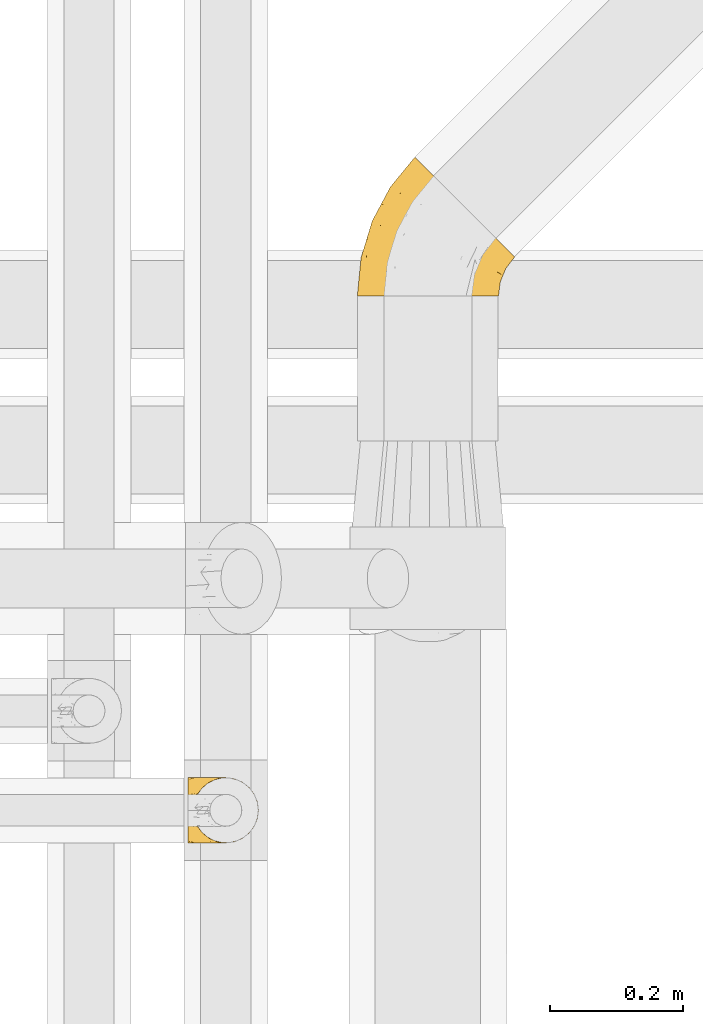
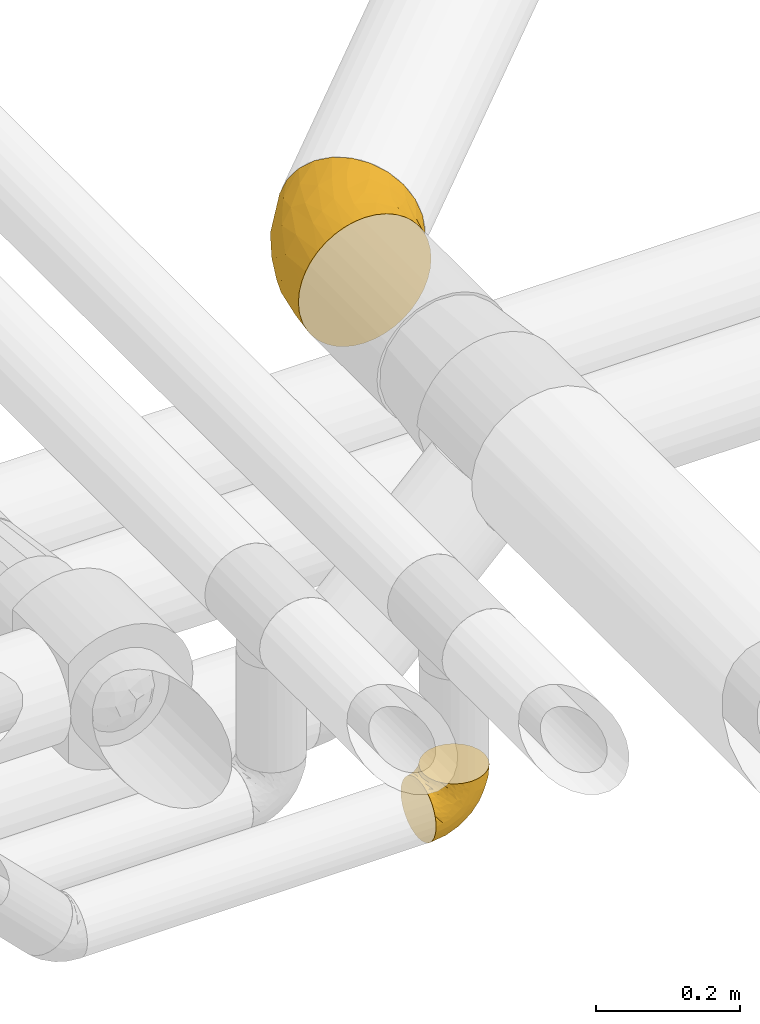
# One storey, part 33 of 93: 2 coverings.
"""IFC2X3 building model written with IfcOpenShell, lengths in millimetres."""

from ifc_helpers import new_model, entity, si_unit, converted_unit, derived_unit, direction, frame, origin, place, context, subcontext, project, spatial, faceted_brep, element, save


model = new_model("IFC2X3")

# Units and contexts
model_context = context("Model", 3, precision=0.01, world=origin(), true_north=direction((6.12303176911189e-17, 1.0)))
body_context = subcontext(model_context, "Body", "Model", "MODEL_VIEW")
ifc_project = project(units=[si_unit("LENGTHUNIT", "METRE", prefix="MILLI"), si_unit("AREAUNIT", "SQUARE_METRE"), si_unit("VOLUMEUNIT", "CUBIC_METRE"), converted_unit("PLANEANGLEUNIT", "DEGREE", entity("IfcRatioMeasure", 0.0174532925199433), si_unit("PLANEANGLEUNIT", "RADIAN"), dimensions=[0, 0, 0, 0, 0, 0, 0]), si_unit("MASSUNIT", "GRAM", prefix="KILO"), derived_unit("MASSDENSITYUNIT", [(si_unit("MASSUNIT", "GRAM", prefix="KILO"), 1), (si_unit("LENGTHUNIT", "METRE"), -3)]), derived_unit("MOMENTOFINERTIAUNIT", [(si_unit("LENGTHUNIT", "METRE"), 4)]), si_unit("TIMEUNIT", "SECOND"), si_unit("FREQUENCYUNIT", "HERTZ"), si_unit("THERMODYNAMICTEMPERATUREUNIT", "DEGREE_CELSIUS"), derived_unit("THERMALTRANSMITTANCEUNIT", [(si_unit("MASSUNIT", "GRAM", prefix="KILO"), 1), (si_unit("THERMODYNAMICTEMPERATUREUNIT", "KELVIN"), -1), (si_unit("TIMEUNIT", "SECOND"), -3)]), derived_unit("VOLUMETRICFLOWRATEUNIT", [(si_unit("LENGTHUNIT", "METRE"), 3), (si_unit("TIMEUNIT", "SECOND"), -1)]), derived_unit("MASSFLOWRATEUNIT", [(si_unit("MASSUNIT", "GRAM", prefix="KILO"), 1), (si_unit("TIMEUNIT", "SECOND"), -1)]), derived_unit("ROTATIONALFREQUENCYUNIT", [(si_unit("TIMEUNIT", "SECOND"), -1)]), si_unit("ELECTRICCURRENTUNIT", "AMPERE"), si_unit("ELECTRICVOLTAGEUNIT", "VOLT"), si_unit("POWERUNIT", "WATT"), si_unit("FORCEUNIT", "NEWTON", prefix="KILO"), si_unit("ILLUMINANCEUNIT", "LUX"), si_unit("LUMINOUSFLUXUNIT", "LUMEN"), si_unit("LUMINOUSINTENSITYUNIT", "CANDELA"), derived_unit("USERDEFINED", [(si_unit("MASSUNIT", "GRAM", prefix="KILO"), -1), (si_unit("LENGTHUNIT", "METRE"), -2), (si_unit("TIMEUNIT", "SECOND"), 3), (si_unit("LUMINOUSFLUXUNIT", "LUMEN"), 1)]), derived_unit("LINEARVELOCITYUNIT", [(si_unit("LENGTHUNIT", "METRE"), 1), (si_unit("TIMEUNIT", "SECOND"), -1)]), si_unit("PRESSUREUNIT", "PASCAL"), derived_unit("USERDEFINED", [(si_unit("LENGTHUNIT", "METRE"), -2), (si_unit("MASSUNIT", "GRAM", prefix="KILO"), 1), (si_unit("TIMEUNIT", "SECOND"), -2)]), derived_unit("LINEARFORCEUNIT", [(si_unit("MASSUNIT", "GRAM", prefix="KILO"), 1), (si_unit("LENGTHUNIT", "METRE"), 1), (si_unit("TIMEUNIT", "SECOND"), -2), (si_unit("LENGTHUNIT", "METRE"), -1)]), derived_unit("PLANARFORCEUNIT", [(si_unit("MASSUNIT", "GRAM", prefix="KILO"), 1), (si_unit("LENGTHUNIT", "METRE"), 1), (si_unit("TIMEUNIT", "SECOND"), -2), (si_unit("LENGTHUNIT", "METRE"), -2)])], contexts=[model_context])

# Site, building, storey
site_placement = place(None, origin())
site = spatial("IfcSite", under=ifc_project, at=site_placement, CompositionType="ELEMENT")
building_placement = place(site_placement, origin())
building = spatial("IfcBuilding", under=site, at=building_placement, CompositionType="ELEMENT")
storey_placement = place(building_placement, frame((0.0, 0.0, -4200.0)))
storey = spatial("IfcBuildingStorey", under=building, at=storey_placement, CompositionType="ELEMENT", Elevation=-4200.0)

# Coverings
covering_1_placement = place(storey_placement, frame((24871.2, 9485.44, 2891.9)))
element("IfcCovering", 1, at=covering_1_placement, inside=storey, Name=":ADSK_", ObjectType=":ADSK_", PredefinedType="INSULATION", context=body_context, shape_type="Brep", body=[
    faceted_brep([(202.99, 1.6, 156.45), (194.25, 1.6, 170.7), (183.4, 1.6, 183.4), (170.69, 1.6, 194.26), (156.45, 1.6, 202.99), (141.01, 1.6, 209.38), (124.76, 1.6, 213.28), (108.1, 1.6, 214.6), (91.43, 1.6, 213.28), (75.18, 1.6, 209.38), (59.74, 1.6, 202.99), (45.49, 1.6, 194.25), (32.79, 1.6, 183.4), (21.93, 1.6, 170.69), (13.2, 1.6, 156.45), (6.81, 1.6, 141.01), (2.91, 1.6, 124.76), (1.6, 1.6, 108.1), (2.91, 1.6, 91.43), (6.81, 1.6, 75.18), (13.21, 1.6, 59.74), (21.94, 1.6, 45.49), (32.79, 1.6, 32.79), (45.5, 1.6, 21.93), (59.74, 1.6, 13.2), (75.18, 1.6, 6.81), (91.43, 1.6, 2.91), (108.1, 1.6, 1.6), (124.76, 1.6, 2.91), (141.01, 1.6, 6.81), (156.45, 1.6, 13.21), (170.7, 1.6, 21.94), (183.4, 1.6, 32.79), (194.26, 1.6, 45.5), (202.99, 1.6, 59.74), (209.38, 1.6, 75.18), (213.28, 1.6, 91.43), (214.6, 1.6, 108.1), (213.28, 1.6, 124.76), (209.38, 1.6, 141.01), (239.05, 60.64, 108.1), (236.49, 63.2, 80.53), (228.96, 70.73, 54.85), (216.99, 82.7, 32.79), (201.4, 98.29, 15.86), (183.24, 116.45, 5.22), (163.74, 135.95, 1.6), (144.25, 155.44, 5.22), (126.09, 173.6, 15.86), (110.49, 189.2, 32.79), (98.53, 201.16, 54.85), (91.0, 208.69, 80.53), (88.44, 211.25, 108.1), (91.0, 208.69, 135.66), (98.53, 201.16, 161.35), (110.49, 189.2, 183.4), (126.09, 173.6, 200.33), (144.25, 155.44, 210.97), (163.74, 135.95, 214.6), (183.24, 116.45, 210.97), (201.4, 98.29, 200.33), (216.99, 82.7, 183.4), (228.96, 70.73, 161.35), (236.49, 63.2, 135.66), (40.02, 140.15, 135.49), (51.56, 166.32, 108.1), (24.16, 115.06, 108.1), (15.5, 61.76, 147.54), (15.99, 86.83, 127.59), (36.79, 108.91, 160.91), (56.03, 116.89, 180.48), (66.52, 156.38, 167.28), (32.39, 61.6, 175.57), (52.38, 49.32, 195.88), (95.65, 65.5, 212.24), (118.18, 110.42, 212.65), (96.0, 110.59, 206.95), (70.9, 55.89, 205.26), (122.56, 74.31, 214.6), (140.12, 107.15, 214.6), (86.94, 146.0, 191.83), (111.75, 38.66, 214.6), (7.29, 59.44, 108.1), (67.02, 96.25, 196.28), (165.04, 86.73, 209.66), (139.8, 57.35, 212.26), (161.73, 52.29, 204.85), (187.33, 70.88, 196.53), (175.51, 26.17, 192.48), (199.51, 24.3, 166.83), (191.13, 41.82, 182.99), (144.12, 31.02, 209.27), (208.01, 61.11, 176.02), (218.82, 34.43, 130.14), (217.44, 23.21, 108.1), (225.78, 43.35, 108.1), (212.07, 38.31, 153.23), (177.44, 46.98, 195.33), (218.82, 34.43, 86.05), (171.72, 26.98, 20.86), (178.38, 51.18, 20.39), (189.0, 29.39, 34.97), (158.59, 60.61, 8.81), (143.71, 38.94, 6.26), (212.07, 38.31, 62.96), (202.39, 57.04, 37.12), (191.66, 75.31, 20.47), (144.06, 74.93, 3.38), (122.56, 74.31, 1.6), (164.48, 86.23, 6.47), (140.12, 107.15, 1.6), (111.75, 38.66, 1.6), (108.85, 99.93, 4.17), (20.65, 82.89, 69.12), (45.44, 106.25, 41.95), (27.92, 55.5, 44.59), (71.93, 158.91, 44.6), (108.61, 136.75, 10.55), (86.07, 52.08, 5.33), (39.51, 140.35, 82.82), (78.4, 134.99, 25.33), (61.34, 164.03, 64.4), (15.77, 86.92, 89.94), (43.7, 60.34, 28.79), (66.99, 47.76, 11.88), (81.16, 93.56, 11.86)], [[[0, 1, 2, 3, 4, 5, 6, 7, 8, 9, 10, 11, 12, 13, 14, 15, 16, 17, 18, 19, 20, 21, 22, 23, 24, 25, 26, 27, 28, 29, 30, 31, 32, 33, 34, 35, 36, 37, 38, 39]], [[40, 41, 42, 43, 44, 45, 46, 47, 48, 49, 50, 51, 52, 53, 54, 55, 56, 57, 58, 59, 60, 61, 62, 63]], [[64, 65, 66]], [[65, 53, 52]], [[67, 68, 16]], [[67, 69, 64]], [[69, 70, 71]], [[68, 64, 66]], [[67, 72, 69]], [[69, 72, 70]], [[72, 73, 70]], [[74, 9, 8]], [[75, 58, 57]], [[76, 77, 74]], [[74, 77, 9]], [[78, 79, 75]], [[55, 71, 80]], [[76, 74, 75]], [[81, 78, 74]], [[73, 12, 11]], [[80, 76, 56]], [[13, 12, 72]], [[68, 66, 82]], [[76, 83, 77]], [[72, 67, 13]], [[67, 14, 13]], [[64, 68, 67]], [[73, 72, 12]], [[16, 15, 67]], [[16, 82, 17]], [[76, 80, 83]], [[64, 71, 54]], [[54, 53, 64]], [[71, 70, 80]], [[74, 8, 81]], [[7, 81, 8]], [[74, 78, 75]], [[53, 65, 64]], [[77, 10, 9]], [[83, 73, 77]], [[71, 55, 54]], [[80, 70, 83]], [[10, 77, 73]], [[56, 76, 57]], [[16, 68, 82]], [[15, 14, 67]], [[55, 80, 56]], [[64, 69, 71]], [[73, 83, 70]], [[10, 73, 11]], [[58, 75, 79]], [[57, 76, 75]], [[78, 84, 79]], [[59, 58, 79]], [[85, 84, 78]], [[84, 86, 87]], [[59, 79, 84]], [[60, 87, 61]], [[84, 85, 86]], [[88, 89, 90]], [[85, 91, 86]], [[61, 92, 62]], [[93, 94, 95]], [[38, 93, 39]], [[84, 87, 60]], [[95, 40, 63]], [[63, 96, 93]], [[63, 93, 95]], [[62, 96, 63]], [[97, 88, 90]], [[81, 91, 85]], [[81, 85, 78]], [[4, 88, 91]], [[3, 88, 4]], [[6, 91, 81]], [[89, 88, 2]], [[93, 96, 39]], [[5, 91, 6]], [[7, 6, 81]], [[91, 88, 86]], [[92, 89, 96]], [[97, 86, 88]], [[89, 2, 1]], [[37, 94, 38]], [[93, 38, 94]], [[60, 59, 84]], [[90, 92, 87]], [[0, 89, 1]], [[2, 88, 3]], [[39, 89, 0]], [[89, 39, 96]], [[96, 62, 92]], [[92, 90, 89]], [[5, 4, 91]], [[90, 87, 97]], [[87, 92, 61]], [[87, 86, 97]], [[98, 41, 95]], [[99, 100, 101]], [[94, 98, 95]], [[102, 99, 103]], [[104, 105, 42]], [[95, 41, 40]], [[34, 101, 104]], [[101, 105, 104]], [[105, 106, 43]], [[107, 103, 108]], [[44, 109, 45]], [[46, 45, 110]], [[45, 109, 110]], [[101, 100, 105]], [[106, 100, 102]], [[107, 110, 109]], [[106, 109, 44]], [[100, 99, 102]], [[35, 98, 36]], [[30, 103, 99]], [[44, 43, 106]], [[34, 104, 35]], [[98, 35, 104]], [[101, 34, 33]], [[41, 104, 42]], [[99, 101, 32]], [[31, 99, 32]], [[108, 103, 111]], [[33, 32, 101]], [[109, 102, 107]], [[29, 103, 30]], [[106, 105, 100]], [[103, 29, 111]], [[41, 98, 104]], [[43, 42, 105]], [[28, 27, 111]], [[29, 28, 111]], [[30, 99, 31]], [[36, 98, 94]], [[103, 107, 102]], [[36, 94, 37]], [[110, 107, 108]], [[106, 102, 109]], [[112, 47, 46]], [[113, 114, 115]], [[20, 115, 21]], [[112, 46, 110]], [[50, 49, 116]], [[47, 117, 48]], [[26, 118, 111]], [[108, 112, 110]], [[66, 65, 119]], [[120, 114, 116]], [[65, 52, 51]], [[51, 121, 119]], [[121, 116, 114]], [[119, 121, 113]], [[113, 122, 119]], [[48, 120, 49]], [[23, 123, 124]], [[116, 121, 50]], [[114, 113, 121]], [[19, 18, 122]], [[25, 118, 26]], [[120, 116, 49]], [[125, 112, 118]], [[119, 122, 66]], [[123, 120, 125]], [[118, 124, 125]], [[22, 21, 115]], [[121, 51, 50]], [[65, 51, 119]], [[23, 22, 123]], [[117, 120, 48]], [[22, 115, 123]], [[123, 115, 114]], [[113, 20, 19]], [[25, 24, 124]], [[122, 82, 66]], [[18, 17, 82]], [[120, 123, 114]], [[112, 125, 117]], [[122, 18, 82]], [[123, 125, 124]], [[115, 20, 113]], [[118, 112, 108]], [[26, 111, 27]], [[122, 113, 19]], [[118, 108, 111]], [[25, 124, 118]], [[124, 24, 23]], [[112, 117, 47]], [[120, 117, 125]]]),
])
covering_2_placement = place(storey_placement, frame((24615.86, 8660.4, 2649.25)))
element("IfcCovering", 2, at=covering_2_placement, inside=storey, Name=":ADSK_", ObjectType=":ADSK_", PredefinedType="INSULATION", context=body_context, shape_type="Brep", body=[
    faceted_brep([(1.6, 99.9, 50.75), (1.6, 98.66, 39.8), (1.6, 95.02, 29.41), (1.6, 89.17, 20.09), (1.6, 81.38, 12.31), (1.6, 72.06, 6.46), (1.6, 61.68, 2.83), (1.6, 50.75, 1.6), (1.6, 39.8, 2.83), (1.6, 29.41, 6.47), (1.6, 20.09, 12.32), (1.6, 12.31, 20.11), (1.6, 6.46, 29.43), (1.6, 2.83, 39.81), (1.6, 1.6, 50.75), (1.6, 2.24, 56.45), (1.6, 2.83, 61.69), (1.6, 4.65, 66.88), (1.6, 6.47, 72.08), (1.6, 12.32, 81.4), (1.6, 20.11, 89.18), (1.6, 29.43, 95.03), (1.6, 39.81, 98.66), (1.6, 50.75, 99.9), (1.6, 61.69, 98.66), (1.6, 72.08, 95.02), (1.6, 81.4, 89.17), (1.6, 89.18, 81.38), (1.6, 95.03, 72.06), (1.6, 96.85, 66.87), (1.6, 98.66, 61.68), (1.6, 99.25, 56.45), (1.6, 99.57, 53.6), (11.12, 38.02, 107.75), (16.03, 26.17, 107.75), (19.94, 21.08, 107.75), (23.84, 15.99, 107.75), (28.93, 12.09, 107.75), (34.02, 8.18, 107.75), (39.95, 5.73, 107.75), (45.87, 3.27, 107.75), (52.86, 2.35, 107.75), (55.73, 1.97, 107.75), (58.6, 1.6, 107.75), (71.32, 3.27, 107.75), (83.17, 8.18, 107.75), (93.35, 15.99, 107.75), (101.16, 26.17, 107.75), (106.07, 38.02, 107.75), (107.75, 50.75, 107.75), (106.07, 63.47, 107.75), (101.16, 75.32, 107.75), (93.35, 85.5, 107.75), (83.17, 93.31, 107.75), (71.32, 98.22, 107.75), (58.6, 99.9, 107.75), (52.86, 99.14, 107.75), (45.87, 98.22, 107.75), (39.95, 95.77, 107.75), (34.02, 93.31, 107.75), (28.93, 89.4, 107.75), (23.84, 85.5, 107.75), (19.94, 80.41, 107.75), (16.03, 75.32, 107.75), (11.12, 63.47, 107.75), (9.45, 50.75, 107.75), (81.82, 59.31, 39.38), (84.02, 73.08, 49.75), (93.05, 63.72, 57.38), (102.55, 50.75, 74.94), (104.83, 58.64, 85.97), (105.83, 50.75, 95.66), (91.87, 76.74, 67.82), (101.74, 67.68, 83.09), (97.07, 78.92, 89.16), (38.45, 94.31, 37.01), (22.17, 98.76, 43.46), (42.04, 98.4, 51.79), (77.69, 94.57, 85.58), (75.76, 89.91, 62.84), (62.11, 96.32, 62.77), (66.08, 98.79, 88.17), (54.26, 99.9, 85.93), (55.35, 99.9, 91.42), (56.44, 99.9, 96.91), (56.98, 99.9, 99.62), (57.52, 99.9, 102.33), (87.84, 87.31, 82.57), (19.41, 95.61, 32.75), (48.89, 60.43, 13.79), (26.34, 65.24, 6.77), (44.55, 72.87, 16.46), (23.41, 99.9, 55.08), (28.03, 99.9, 58.17), (32.65, 99.9, 61.26), (37.28, 99.9, 64.35), (41.9, 99.9, 67.44), (20.6, 90.65, 24.18), (63.36, 63.14, 23.37), (62.21, 91.89, 49.76), (19.94, 75.25, 9.84), (13.68, 50.75, 3.51), (80.85, 82.18, 55.75), (66.53, 85.08, 42.34), (71.06, 76.93, 37.78), (63.99, 50.75, 21.87), (75.73, 50.75, 33.61), (26.77, 83.02, 17.1), (4.31, 99.9, 51.28), (7.01, 99.9, 51.82), (12.43, 99.9, 52.9), (17.92, 99.9, 53.99), (43.43, 87.13, 28.01), (56.23, 80.85, 28.99), (54.97, 99.17, 69.9), (34.4, 50.75, 6.79), (44.99, 99.9, 72.06), (48.08, 99.9, 76.69), (51.17, 99.9, 81.31), (87.47, 50.75, 45.35), (74.55, 67.61, 34.79), (60.86, 72.25, 25.72), (49.19, 50.75, 14.33), (95.01, 50.75, 60.15), (10.27, 98.69, 62.38), (48.79, 99.01, 100.57), (45.16, 98.79, 91.06), (44.99, 98.29, 97.66), (6.17, 68.51, 97.55), (7.65, 76.82, 93.65), (21.59, 98.54, 66.85), (19.96, 99.3, 61.93), (21.0, 83.57, 101.4), (27.2, 89.47, 100.07), (14.83, 75.76, 101.36), (19.7, 84.86, 95.94), (10.93, 75.89, 96.3), (9.63, 64.77, 101.98), (19.97, 90.83, 85.88), (21.13, 94.62, 78.88), (14.14, 90.37, 82.8), (30.2, 91.18, 102.58), (36.65, 95.55, 96.59), (8.12, 88.65, 82.88), (9.93, 84.11, 88.57), (24.62, 91.75, 88.67), (11.87, 96.86, 69.08), (7.15, 50.75, 102.19), (5.32, 58.97, 100.06), (26.68, 98.37, 70.56), (13.92, 83.91, 91.07), (30.67, 97.52, 77.56), (42.89, 98.76, 86.38), (34.04, 95.26, 91.79), (36.6, 98.04, 81.71), (26.41, 90.65, 94.11), (10.07, 93.51, 76.09), (15.83, 94.16, 76.91), (41.99, 99.1, 81.44), (14.83, 25.73, 101.37), (26.4, 10.84, 94.12), (21.01, 17.92, 101.41), (19.71, 16.64, 95.96), (5.72, 30.44, 96.22), (21.6, 2.95, 66.85), (19.96, 2.19, 61.94), (28.03, 1.6, 58.17), (11.87, 4.63, 69.1), (9.93, 17.39, 88.58), (58.06, 1.6, 105.04), (56.44, 1.6, 96.91), (57.52, 1.6, 102.33), (8.13, 12.86, 82.9), (14.15, 11.13, 82.82), (44.99, 3.2, 97.66), (36.65, 5.94, 96.59), (30.2, 10.31, 102.58), (10.06, 8.0, 76.13), (15.83, 7.34, 76.93), (48.79, 2.48, 100.57), (42.89, 2.73, 86.38), (45.38, 2.64, 90.86), (12.43, 1.6, 52.9), (10.28, 2.8, 62.39), (9.64, 36.71, 101.98), (55.35, 1.6, 91.42), (54.26, 1.6, 85.93), (6.05, 38.59, 99.49), (7.01, 1.6, 51.82), (9.72, 1.6, 52.36), (32.65, 1.6, 61.26), (26.68, 3.12, 70.56), (13.92, 17.59, 91.09), (37.28, 1.6, 64.35), (30.66, 3.98, 77.6), (21.14, 6.87, 78.89), (36.59, 3.45, 81.71), (24.6, 9.76, 88.69), (17.92, 1.6, 53.99), (23.41, 1.6, 55.08), (10.93, 25.62, 96.31), (19.97, 10.67, 85.9), (41.99, 2.39, 81.45), (48.08, 1.6, 76.69), (34.04, 6.23, 91.79), (27.21, 12.02, 100.07), (51.17, 1.6, 81.31), (44.99, 1.6, 72.06), (41.9, 1.6, 67.44), (55.26, 2.4, 69.6), (104.83, 42.85, 85.97), (87.84, 14.18, 82.57), (75.91, 11.56, 63.16), (80.84, 19.27, 55.81), (91.87, 24.75, 67.81), (83.98, 28.37, 49.73), (19.16, 5.95, 32.55), (22.37, 2.79, 43.23), (66.08, 2.71, 88.17), (93.05, 37.78, 57.38), (101.74, 33.81, 83.08), (97.07, 22.57, 89.16), (77.69, 6.92, 85.58), (44.55, 28.61, 16.46), (26.34, 36.24, 6.77), (48.9, 41.05, 13.8), (70.99, 24.55, 37.71), (74.55, 33.88, 34.8), (37.8, 7.11, 36.83), (81.82, 42.18, 39.38), (26.77, 18.46, 17.12), (20.6, 10.84, 24.19), (56.15, 20.69, 28.89), (60.85, 29.27, 25.69), (42.06, 3.1, 51.77), (57.03, 9.18, 45.66), (63.4, 38.38, 23.39), (19.94, 26.23, 9.85), (43.59, 14.34, 28.11), (62.61, 5.46, 62.27), (66.52, 16.39, 42.35)], [[[0, 1, 2, 3, 4, 5, 6, 7, 8, 9, 10, 11, 12, 13, 14, 15, 16, 17, 18, 19, 20, 21, 22, 23, 24, 25, 26, 27, 28, 29, 30, 31, 32]], [[33, 34, 35, 36, 37, 38, 39, 40, 41, 42, 43, 44, 45, 46, 47, 48, 49, 50, 51, 52, 53, 54, 55, 56, 57, 58, 59, 60, 61, 62, 63, 64, 65]], [[66, 67, 68]], [[69, 70, 71]], [[68, 72, 73]], [[73, 72, 74]], [[75, 76, 77]], [[78, 79, 80]], [[51, 50, 73]], [[81, 82, 83, 84, 85, 86, 55]], [[52, 87, 53]], [[74, 52, 51]], [[2, 1, 88]], [[89, 90, 91]], [[77, 92, 93, 94, 95, 96]], [[55, 54, 81]], [[78, 53, 87]], [[5, 90, 6]], [[88, 76, 75]], [[97, 3, 2]], [[89, 91, 98]], [[99, 80, 79]], [[90, 5, 100]], [[74, 87, 52]], [[100, 5, 4]], [[90, 101, 6]], [[79, 102, 103]], [[102, 67, 104]], [[105, 98, 106]], [[107, 4, 3]], [[76, 0, 108, 109, 110, 111, 92]], [[107, 112, 113]], [[114, 77, 96]], [[89, 115, 90]], [[114, 96, 116, 117, 118, 82]], [[75, 97, 88]], [[119, 66, 68]], [[50, 71, 70]], [[100, 91, 90]], [[99, 77, 80]], [[102, 104, 103]], [[97, 107, 3]], [[80, 81, 78]], [[107, 97, 112]], [[68, 73, 70]], [[66, 98, 120]], [[78, 81, 54]], [[114, 81, 80]], [[53, 78, 54]], [[78, 87, 79]], [[102, 87, 72]], [[79, 103, 99]], [[4, 107, 100]], [[91, 100, 107]], [[88, 97, 2]], [[112, 97, 75]], [[99, 112, 75]], [[103, 104, 113]], [[91, 121, 98]], [[89, 105, 122, 115]], [[101, 90, 115]], [[101, 7, 6]], [[88, 1, 76]], [[0, 76, 1]], [[92, 77, 76]], [[73, 74, 51]], [[87, 74, 72]], [[81, 114, 82]], [[77, 114, 80]], [[87, 102, 79]], [[67, 102, 72]], [[68, 67, 72]], [[67, 120, 104]], [[120, 121, 104]], [[104, 121, 113]], [[121, 120, 98]], [[91, 107, 113]], [[91, 113, 121]], [[103, 113, 112]], [[106, 98, 66]], [[105, 89, 98]], [[106, 66, 119]], [[67, 66, 120]], [[68, 69, 123, 119]], [[50, 49, 71]], [[50, 70, 73]], [[112, 99, 103]], [[77, 99, 75]], [[69, 68, 70]], [[29, 124, 110]], [[84, 83, 125]], [[126, 82, 118]], [[59, 58, 127]], [[25, 128, 129]], [[130, 93, 131]], [[132, 62, 133]], [[134, 135, 136]], [[137, 65, 64]], [[64, 134, 137]], [[138, 139, 140]], [[111, 110, 124, 92]], [[134, 136, 137]], [[134, 64, 63]], [[141, 60, 142]], [[125, 58, 57]], [[143, 144, 140]], [[143, 26, 144]], [[127, 83, 82]], [[28, 124, 29]], [[32, 31, 30, 110, 109, 108, 0]], [[30, 29, 110]], [[135, 145, 138]], [[28, 146, 124]], [[57, 56, 55, 86, 85, 84]], [[147, 148, 23]], [[24, 23, 148]], [[25, 144, 26]], [[95, 94, 149]], [[24, 128, 25]], [[150, 138, 144]], [[124, 146, 131]], [[127, 58, 125]], [[151, 149, 139]], [[127, 126, 142]], [[142, 59, 127]], [[152, 142, 126]], [[153, 154, 155]], [[153, 133, 141]], [[146, 28, 27]], [[143, 156, 27]], [[157, 149, 130]], [[61, 133, 62]], [[134, 132, 135]], [[148, 128, 24]], [[65, 137, 147]], [[147, 137, 148]], [[128, 137, 136]], [[137, 128, 148]], [[128, 136, 129]], [[150, 129, 136]], [[25, 129, 144]], [[158, 152, 117]], [[152, 118, 117]], [[153, 142, 152]], [[158, 116, 154]], [[145, 151, 138]], [[153, 152, 158]], [[133, 153, 155]], [[133, 155, 132]], [[153, 141, 142]], [[135, 132, 155]], [[134, 63, 132]], [[145, 135, 155]], [[135, 138, 150]], [[155, 154, 145]], [[151, 154, 96]], [[154, 151, 145]], [[149, 94, 130]], [[82, 126, 127]], [[118, 152, 126]], [[151, 96, 95]], [[139, 149, 157]], [[151, 95, 149]], [[93, 92, 131]], [[130, 146, 156]], [[130, 94, 93]], [[84, 125, 57]], [[127, 125, 83]], [[140, 139, 157]], [[151, 139, 138]], [[140, 157, 143]], [[138, 140, 144]], [[156, 143, 157]], [[27, 26, 143]], [[130, 156, 157]], [[146, 27, 156]], [[132, 63, 62]], [[124, 131, 92]], [[130, 131, 146]], [[129, 150, 144]], [[135, 150, 136]], [[60, 141, 61]], [[60, 59, 142]], [[133, 61, 141]], [[116, 96, 154]], [[153, 158, 154]], [[158, 117, 116]], [[34, 33, 159]], [[160, 161, 162]], [[22, 21, 163]], [[164, 165, 166]], [[19, 18, 167]], [[168, 21, 20]], [[169, 43, 42, 41, 40, 170, 171]], [[172, 173, 168]], [[174, 38, 175]], [[37, 36, 176]], [[177, 164, 178]], [[40, 179, 170]], [[180, 181, 175]], [[17, 182, 183]], [[65, 147, 184]], [[185, 174, 186]], [[23, 22, 187]], [[174, 39, 38]], [[15, 14, 188, 189, 182, 16]], [[179, 40, 39]], [[190, 191, 164]], [[192, 163, 168]], [[33, 184, 159]], [[178, 173, 172]], [[193, 194, 191]], [[18, 183, 167]], [[173, 178, 195]], [[196, 197, 194]], [[198, 199, 183, 182]], [[182, 17, 16]], [[18, 17, 183]], [[200, 159, 184]], [[192, 168, 201]], [[187, 163, 200]], [[202, 203, 180]], [[185, 179, 174]], [[160, 204, 205]], [[206, 181, 180]], [[206, 180, 203]], [[199, 165, 183]], [[165, 164, 167]], [[172, 177, 178]], [[200, 192, 162]], [[205, 161, 160]], [[65, 184, 33]], [[163, 187, 22]], [[175, 204, 180]], [[174, 181, 186]], [[204, 196, 202]], [[197, 160, 162]], [[196, 207, 202]], [[37, 176, 175]], [[196, 204, 160]], [[176, 204, 175]], [[205, 35, 161]], [[34, 159, 161]], [[162, 161, 159]], [[200, 162, 159]], [[197, 162, 201]], [[194, 197, 201]], [[196, 160, 197]], [[191, 195, 178]], [[208, 196, 194]], [[186, 181, 206]], [[175, 181, 174]], [[191, 190, 193]], [[193, 208, 194]], [[195, 194, 201]], [[178, 164, 191]], [[168, 163, 21]], [[166, 165, 199]], [[166, 190, 164]], [[187, 200, 184]], [[184, 147, 187]], [[23, 187, 147]], [[174, 179, 39]], [[170, 179, 185]], [[194, 195, 191]], [[173, 201, 168]], [[201, 173, 195]], [[172, 168, 20]], [[20, 19, 172]], [[177, 172, 19]], [[19, 167, 177]], [[164, 177, 167]], [[35, 205, 36]], [[35, 34, 161]], [[183, 165, 167]], [[162, 192, 201]], [[163, 192, 200]], [[175, 38, 37]], [[36, 205, 176]], [[204, 176, 205]], [[204, 202, 180]], [[207, 196, 208]], [[207, 203, 202]], [[209, 186, 206, 203, 207, 208]], [[48, 210, 71]], [[211, 212, 213]], [[214, 213, 215]], [[216, 217, 13]], [[218, 43, 169, 171, 170, 185, 186]], [[219, 220, 214]], [[47, 46, 221]], [[210, 48, 220]], [[211, 222, 212]], [[222, 45, 44]], [[221, 220, 47]], [[47, 220, 48]], [[221, 211, 214]], [[223, 224, 225]], [[211, 46, 45]], [[226, 227, 215]], [[43, 218, 44]], [[217, 216, 228]], [[215, 229, 219]], [[14, 13, 217]], [[224, 9, 8]], [[10, 230, 11]], [[11, 231, 12]], [[232, 223, 233]], [[234, 208, 193, 190, 166, 199]], [[235, 234, 228]], [[222, 44, 218]], [[106, 229, 236]], [[224, 237, 9]], [[231, 238, 228]], [[9, 237, 10]], [[115, 224, 101]], [[239, 234, 235]], [[231, 11, 230]], [[223, 230, 237]], [[224, 8, 101]], [[223, 236, 233]], [[225, 115, 122, 105]], [[216, 12, 231]], [[209, 234, 239]], [[210, 219, 69]], [[219, 214, 215]], [[229, 119, 219]], [[209, 218, 186]], [[239, 212, 222]], [[239, 222, 218]], [[45, 222, 211]], [[235, 212, 239]], [[213, 212, 240]], [[223, 237, 224]], [[230, 10, 237]], [[238, 231, 230]], [[216, 231, 228]], [[232, 230, 223]], [[235, 238, 240]], [[115, 225, 224]], [[233, 236, 227]], [[8, 7, 101]], [[234, 209, 208]], [[218, 209, 239]], [[217, 228, 234]], [[13, 12, 216]], [[234, 199, 217]], [[217, 199, 198, 182, 189, 188, 14]], [[211, 221, 46]], [[220, 221, 214]], [[71, 210, 69]], [[71, 49, 48]], [[219, 210, 220]], [[226, 215, 213]], [[211, 213, 214]], [[226, 213, 240]], [[215, 227, 229]], [[232, 240, 238]], [[233, 227, 226]], [[232, 233, 226]], [[236, 223, 225]], [[240, 232, 226]], [[232, 238, 230]], [[225, 105, 236]], [[236, 105, 106]], [[229, 106, 119]], [[69, 219, 119, 123]], [[236, 229, 227]], [[238, 235, 228]], [[212, 235, 240]]]),
])

save(model, "model.ifc")
